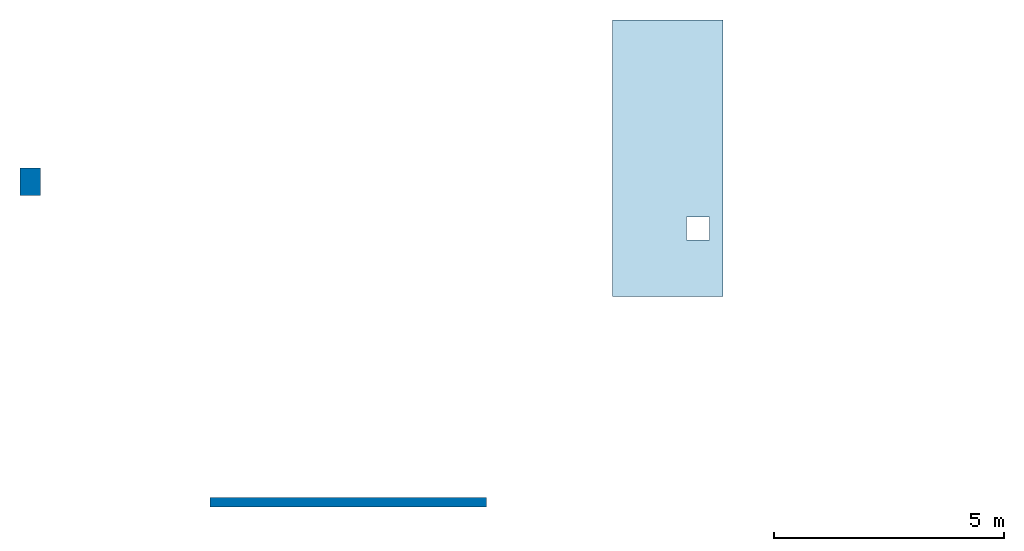
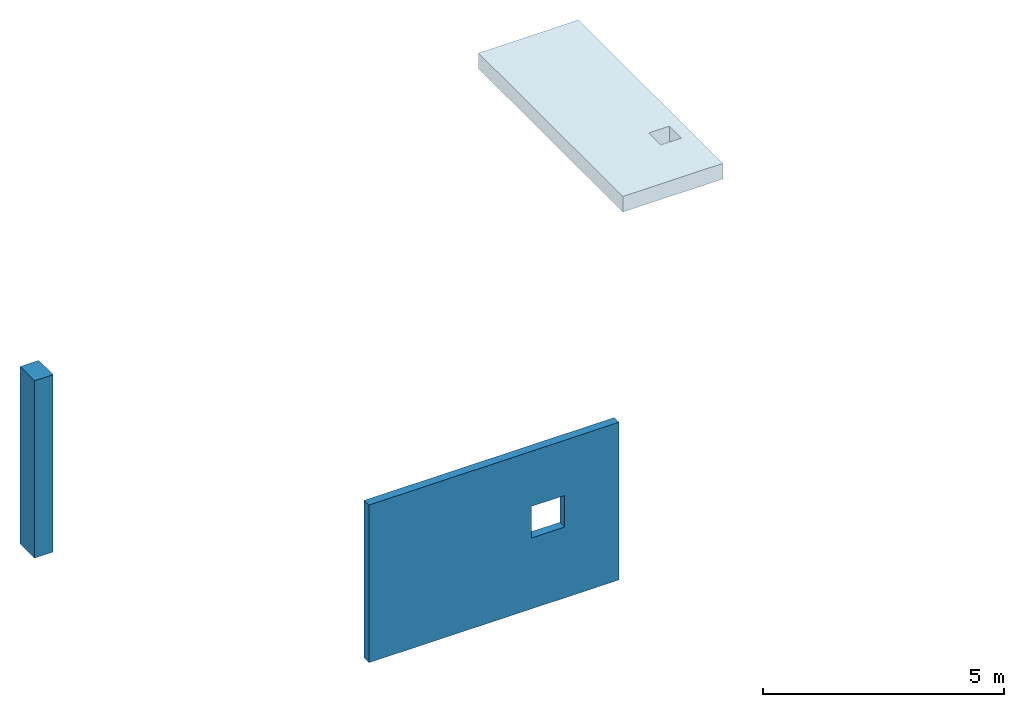
# One storey, part 1 of 2: 1 column, 1 slab, 1 wall, 1 opening.
"""IFC4 building model written with IfcOpenShell, lengths in metres."""

from ifc_helpers import new_model, entity, si_unit, converted_unit, derived_unit, direction, frame, origin, place, context, subcontext, project, spatial, indexed_curve, outline, extrude, polygons, source, transform, mapped, material, layer, layer_set, type_object, type_shapes, element, save


model = new_model("IFC4")

# Units and contexts
model_context = context("Model", 3, precision=1e-05, world=origin(), true_north=direction((6.12303176911189e-17, 1.0)))
body_context = subcontext(model_context, "Body", "Model", "MODEL_VIEW")
ifc_project = project(units=[si_unit("LENGTHUNIT", "METRE"), si_unit("AREAUNIT", "SQUARE_METRE"), si_unit("VOLUMEUNIT", "CUBIC_METRE"), converted_unit("PLANEANGLEUNIT", "DEGREE", entity("IfcRatioMeasure", 0.0174532925199433), si_unit("PLANEANGLEUNIT", "RADIAN"), dimensions=[0, 0, 0, 0, 0, 0, 0]), si_unit("MASSUNIT", "GRAM", prefix="KILO"), derived_unit("MASSDENSITYUNIT", [(si_unit("MASSUNIT", "GRAM", prefix="KILO"), 1), (si_unit("LENGTHUNIT", "METRE"), -3)]), derived_unit("MOMENTOFINERTIAUNIT", [(si_unit("LENGTHUNIT", "METRE"), 4)]), si_unit("TIMEUNIT", "SECOND"), si_unit("FREQUENCYUNIT", "HERTZ"), si_unit("THERMODYNAMICTEMPERATUREUNIT", "DEGREE_CELSIUS"), derived_unit("THERMALTRANSMITTANCEUNIT", [(si_unit("MASSUNIT", "GRAM", prefix="KILO"), 1), (si_unit("THERMODYNAMICTEMPERATUREUNIT", "KELVIN"), -1), (si_unit("TIMEUNIT", "SECOND"), -3)]), derived_unit("VOLUMETRICFLOWRATEUNIT", [(si_unit("LENGTHUNIT", "METRE"), 3), (si_unit("TIMEUNIT", "SECOND"), -1)]), si_unit("ELECTRICCURRENTUNIT", "AMPERE"), si_unit("ELECTRICVOLTAGEUNIT", "VOLT"), si_unit("POWERUNIT", "WATT"), si_unit("FORCEUNIT", "NEWTON", prefix="KILO"), si_unit("ILLUMINANCEUNIT", "LUX"), si_unit("LUMINOUSFLUXUNIT", "LUMEN"), si_unit("LUMINOUSINTENSITYUNIT", "CANDELA"), derived_unit("USERDEFINED", [(si_unit("MASSUNIT", "GRAM", prefix="KILO"), -1), (si_unit("LENGTHUNIT", "METRE"), -2), (si_unit("TIMEUNIT", "SECOND"), 3), (si_unit("LUMINOUSFLUXUNIT", "LUMEN"), 1)]), derived_unit("LINEARVELOCITYUNIT", [(si_unit("LENGTHUNIT", "METRE"), 1), (si_unit("TIMEUNIT", "SECOND"), -1)]), si_unit("PRESSUREUNIT", "PASCAL"), derived_unit("USERDEFINED", [(si_unit("LENGTHUNIT", "METRE"), -2), (si_unit("MASSUNIT", "GRAM", prefix="KILO"), 1), (si_unit("TIMEUNIT", "SECOND"), -2)]), derived_unit("LINEARFORCEUNIT", [(si_unit("MASSUNIT", "GRAM", prefix="KILO"), 1), (si_unit("LENGTHUNIT", "METRE"), 1), (si_unit("TIMEUNIT", "SECOND"), -2), (si_unit("LENGTHUNIT", "METRE"), -1)]), derived_unit("PLANARFORCEUNIT", [(si_unit("MASSUNIT", "GRAM", prefix="KILO"), 1), (si_unit("LENGTHUNIT", "METRE"), 1), (si_unit("TIMEUNIT", "SECOND"), -2), (si_unit("LENGTHUNIT", "METRE"), -2)])], contexts=[model_context])

# Site, building, storey
site_placement = place(None, origin())
site = spatial("IfcSite", under=ifc_project, at=site_placement, CompositionType="ELEMENT")
building_placement = place(site_placement, origin())
building = spatial("IfcBuilding", under=site, at=building_placement, Name="1", CompositionType="ELEMENT")
storey_placement = place(building_placement, origin())
storey = spatial("IfcBuildingStorey", under=building, at=storey_placement, Name="1 korrus", CompositionType="ELEMENT", Elevation=0.0)

# Column
ifc_material_1 = material(Name="EST. C30/37", Category="Materials")
column_type = type_object("IfcColumnType", Name="RB post:450 x 600mm", PredefinedType="COLUMN", material=ifc_material_1)
shared_shape = source(origin(), body_context, "Body", "SweptSolid", [
    extrude(outline(indexed_curve([(-0.3, -0.225), (0.3, -0.225), (0.3, 0.225), (-0.3, 0.225), (-0.3, -0.225)], self_intersect=False)), frame((0.0, 0.0, 0.0), z_axis=(0.0, 0.0, 1.0), x_axis=(0.0, -1.0, 0.0)), (0.0, 0.0, 1.0), 4.5),
])
type_shapes(column_type, [shared_shape])
column_placement = place(storey_placement, frame((-3.9, 6.95750003622717, 0.0)))
element("IfcColumn", 1, at=column_placement, inside=storey, type_object=column_type, material=ifc_material_1, Name="RB post:450 x 600mm", ObjectType="RB post:450 x 600mm", PredefinedType="COLUMN", context=body_context, shape_type="MappedRepresentation", body=[
    mapped(shared_shape, transform((0.0, 0.0, 0.0), scale=1.0)),
])

# Slab
ifc_layer_1 = layer(ifc_material_1, 0.08, Name="EST. C30/37", Category="Materials")
ifc_material_2 = material(Name="EST. Default", Category="Materials")
ifc_layer_2 = layer(ifc_material_2, 0.05, Name="EST. Default", Category="Materials")
ifc_layer_3 = layer(ifc_material_1, 0.265, Name="EST. C30/37", Category="Materials")
ifc_layer_set_1 = layer_set([ifc_layer_1, ifc_layer_2, ifc_layer_3], Name="Floor:VL-01")
slab_type = type_object("IfcSlabType", Name="Floor:VL-01", PredefinedType="FLOOR", material=ifc_layer_set_1)
slab_placement = place(storey_placement, origin())
element("IfcSlab", 2, at=slab_placement, inside=storey, type_object=slab_type, material=ifc_layer_set_1, Name="Floor:VL-01", ObjectType="Floor:VL-01", PredefinedType="FLOOR", context=body_context, shape_type="SweptSolid", body=[
    extrude(outline(indexed_curve([(-3.0, -1.2), (3.0, -1.2), (3.0, 1.2), (-3.0, 1.2), (-3.0, -1.2)], self_intersect=False), holes=[indexed_curve([(1.77702384540683, 0.413347785095038), (1.27702384540683, 0.413347785095038), (1.27702384540683, 0.913347785095037), (1.77702384540683, 0.913347785095037), (1.77702384540683, 0.413347785095038)], self_intersect=False)]), frame((9.93366308454254, 7.47160587635352, 5.605), z_axis=(0.0, 0.0, 1.0), x_axis=(0.0, -1.0, 0.0)), (0.0, 0.0, 1.0), 0.395),
])

# Wall, opening
ifc_layer_4 = layer(ifc_material_1, 0.2, Name="EST. C30/37", Category="Materials")
ifc_layer_set_2 = layer_set([ifc_layer_4], Name="Basic Wall:VS-01")
wall_type = type_object("IfcWallType", Name="Basic Wall:VS-01", PredefinedType="NOTDEFINED", material=ifc_layer_set_2)
wall_placement = place(storey_placement, origin())
wall = element("IfcWall", 3, at=wall_placement, inside=storey, type_object=wall_type, material=ifc_layer_set_2, Name="Basic Wall:VS-01", ObjectType="Basic Wall:VS-01", PredefinedType="NOTDEFINED", context=body_context, shape_type="Tessellation", body=[
    polygons([(-4.03399441129861e-24, -0.1, -2.0169972056493e-24), (6.0, -0.1, 2.0169972056493e-24), (6.0, -0.1, 4.0), (4.03399441129861e-24, -0.1, 4.0), (4.7, -0.1, 1.8), (3.9, -0.1, 1.8), (3.9, -0.1, 2.6), (4.7, -0.1, 2.6), (0.0, 0.1, -2.0169972056493e-24), (0.0, 0.1, 4.0), (6.0, 0.1, 4.0), (6.0, 0.1, 2.0169972056493e-24), (4.7, 0.1, 1.8), (4.7, 0.1, 2.6), (3.9, 0.1, 2.6), (3.9, 0.1, 1.8)], [[[1, 2, 3, 4], [6, 7, 8, 5]], [[12, 9, 10, 11], [13, 14, 15, 16]], [[2, 1, 9, 12]], [[15, 14, 8, 7]], [[3, 2, 12, 11]], [[16, 15, 7, 6]], [[4, 3, 11, 10]], [[13, 16, 6, 5]], [[1, 4, 10, 9]], [[14, 13, 5, 8]]], closed=True),
])
opening_placement = place(wall_placement, origin())
element("IfcOpeningElement", 4, at=opening_placement, cuts=wall, Name="Basic Wall:VS-01", ObjectType="Opening", PredefinedType="OPENING", context=body_context, shape_type="SweptSolid", body=[
    extrude(outline(indexed_curve([(-0.4, -0.4), (0.4, -0.4), (0.4, 0.4), (-0.4, 0.4), (-0.4, -0.4)], self_intersect=False)), frame((4.3, -1.42400000000001, 2.2), z_axis=(0.0, 1.0, 0.0), x_axis=(-1.0, 0.0, 0.0)), (0.0, 0.0, 1.0), 3.048),
])

save(model, "model.ifc")
